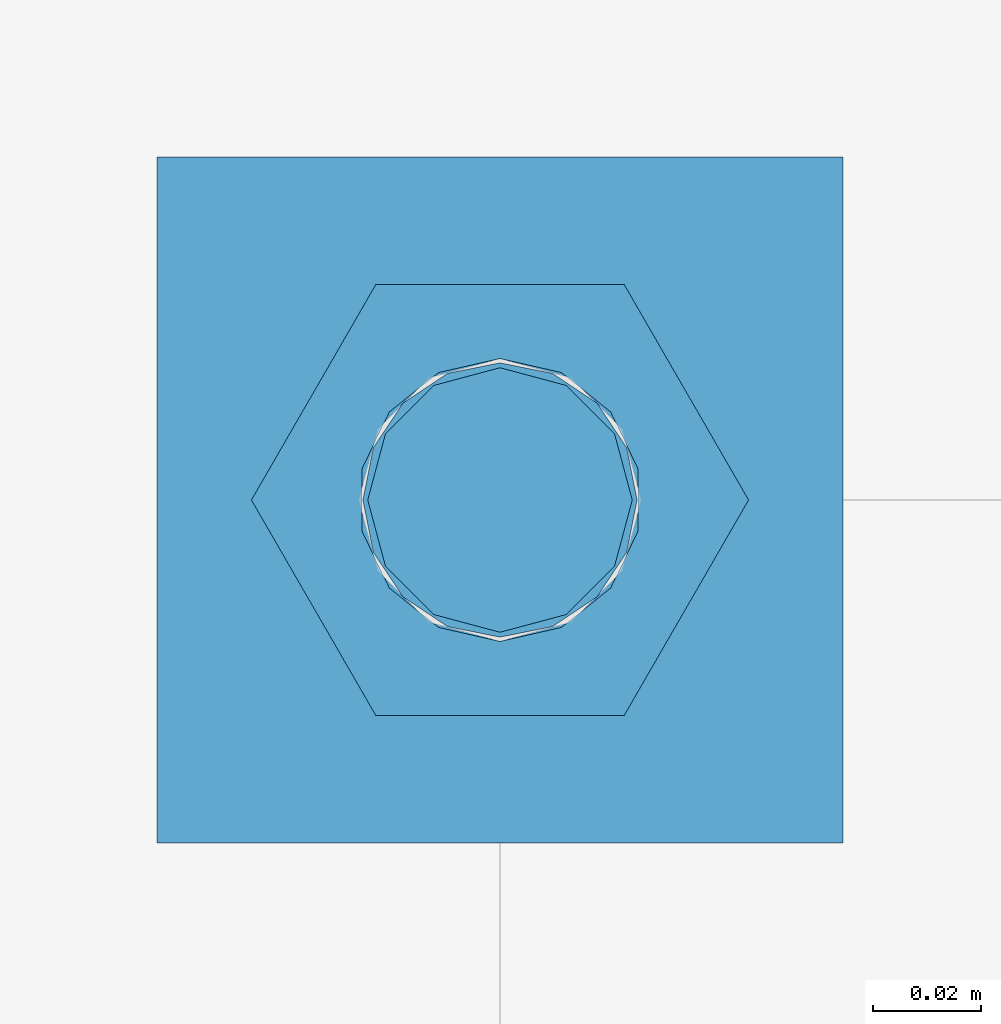
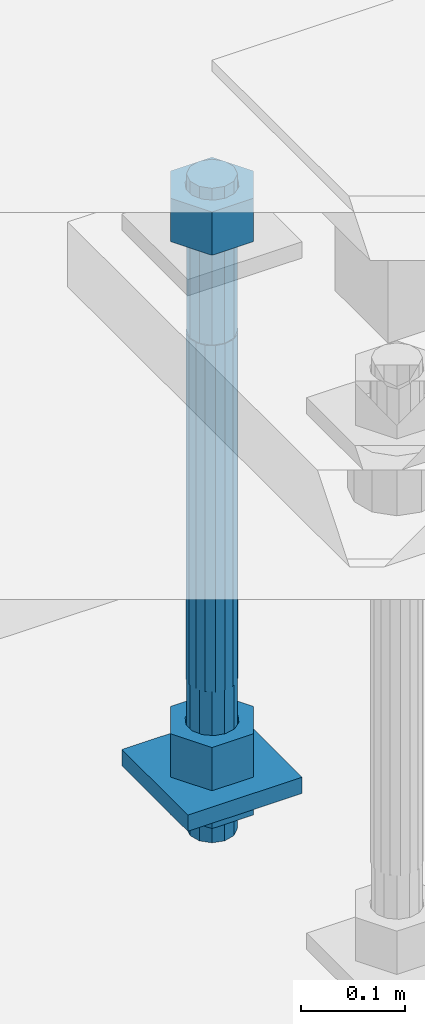
# One storey, part 2772 of 3843: 5 beams, 1 element without a shape of its own.
"""IFC2X3 building model written with IfcOpenShell, lengths in millimetres."""

from ifc_helpers import new_model, si_unit, frame, origin_with_axes, place, context, subcontext, project, spatial, faceted_brep, material, type_object, element, aggregate, save


model = new_model("IFC2X3")

# Units and contexts
model_context = context("Model", 3, precision=1e-05, world=origin_with_axes())
body_context = subcontext(model_context, "Body", "Model", "MODEL_VIEW")
ifc_project = project(units=[si_unit("LENGTHUNIT", "METRE", prefix="MILLI"), si_unit("AREAUNIT", "SQUARE_METRE"), si_unit("VOLUMEUNIT", "CUBIC_METRE"), si_unit("MASSUNIT", "GRAM", prefix="KILO"), si_unit("TIMEUNIT", "SECOND"), si_unit("PLANEANGLEUNIT", "RADIAN"), si_unit("SOLIDANGLEUNIT", "STERADIAN"), si_unit("THERMODYNAMICTEMPERATUREUNIT", "DEGREE_CELSIUS"), si_unit("LUMINOUSINTENSITYUNIT", "LUMEN")], contexts=[model_context])

# Site, building, storey
site_placement = place(None, origin_with_axes())
site = spatial("IfcSite", under=ifc_project, at=site_placement, CompositionType="ELEMENT")
building_placement = place(site_placement, origin_with_axes())
building = spatial("IfcBuilding", under=site, at=building_placement, Name="Undefined", CompositionType="ELEMENT")
storey_placement = place(building_placement, origin_with_axes())
storey = spatial("IfcBuildingStorey", under=building, at=storey_placement, Name="Undefined", CompositionType="ELEMENT", Elevation=0.0)

# Assembly, beams
assembly_placement = place(storey_placement, origin_with_axes())
assembly = element("IfcElementAssembly", 1, at=assembly_placement, inside=storey, Name="TEMPLATE", AssemblyPlace="NOTDEFINED", PredefinedType="RIGID_FRAME")
ifc_material_1 = material(Name="STEEL/A572-50")
beam_type_1 = type_object("IfcBeamType", PredefinedType="NOTDEFINED")
beam_1_placement = place(assembly_placement, frame((118598.95, 52946.2999984741, 29244.925), z_axis=(-1.0, 0.0, 0.0), x_axis=(0.0, -1.0, 0.0)))
beam_1 = element("IfcBeam", 2, at=beam_1_placement, type_object=beam_type_1, material=ifc_material_1, Name="WASHER_PLATE", context=body_context, shape_type="Brep", body=[
    faceted_brep([(0.0, 9.52500000000146, -63.5), (0.0, 9.52500000000146, 63.5), (127.0, 9.52500000000146, 63.5), (127.0, 9.52500000000146, -63.5), (0.0, -9.52500000000146, 63.5), (127.0, -9.52500000000146, 63.5), (0.0, -9.52500000000146, -63.5), (127.0, -9.52500000000146, -63.5)], [[[0, 1, 2, 3]], [[1, 4, 5, 2]], [[4, 6, 7, 5]], [[6, 0, 3, 7]], [[5, 7, 3, 2]], [[6, 4, 1, 0]]]),
])
ifc_material_2 = material(Name="STEEL/A36")
beam_type_2 = type_object("IfcBeamType", Name="2_HALF_NUT", PredefinedType="NOTDEFINED")
beam_2_placement = place(assembly_placement, frame((118598.95, 52882.7999984741, 29235.4), z_axis=(0.0, -1.0, 0.0), x_axis=(0.0, 0.0, -1.0)))
beam_2 = element("IfcBeam", 3, at=beam_2_placement, type_object=beam_type_2, material=ifc_material_2, Name="NUT", ObjectType="2_HALF_NUT", context=body_context, shape_type="Brep", body=[
    faceted_brep([(0.0, -46.0369987487793, 0.0), (0.0, -23.0184993743896, -39.869213104248), (25.4000000000015, -23.0184993743896, -39.869213104248), (25.4000000000015, -46.0369987487793, 0.0), (0.0, 23.0184993743896, -39.869213104248), (25.4000000000015, 23.0184993743896, -39.869213104248), (0.0, 46.0369987487793, 0.0), (25.4000000000015, 46.0369987487793, 0.0), (0.0, 23.0184993743896, 39.869213104248), (25.4000000000015, 23.0184993743896, 39.869213104248), (0.0, -23.0184993743896, 39.869213104248), (25.4000000000015, -23.0184993743896, 39.869213104248), (0.0, 0.0, 26.1940002441406), (0.0, 11.3650617044477, 23.5999013092805), (25.4000000000015, 11.3650617044477, 23.5999013092805), (25.4000000000015, 0.0, 26.1940002441406), (0.0, 20.4791109456419, 16.3316083006721), (25.4000000000015, 20.4791109456419, 16.3316083006721), (0.0, 25.5370200498292, 5.82867859874386), (25.4000000000015, 25.5370200498292, 5.82867859874386), (0.0, 25.5370200498292, -5.82867859874386), (25.4000000000015, 25.5370200498292, -5.82867859874386), (0.0, 20.4791109456419, -16.3316083006721), (25.4000000000015, 20.4791109456419, -16.3316083006721), (0.0, 11.3650617044477, -23.5999013092805), (25.4000000000015, 11.3650617044477, -23.5999013092805), (0.0, 0.0, -26.1940002441406), (25.4000000000015, 0.0, -26.1940002441406), (0.0, -11.3650617044477, -23.5999013092805), (25.4000000000015, -11.3650617044477, -23.5999013092805), (0.0, -20.4791109456419, -16.3316083006721), (25.4000000000015, -20.4791109456419, -16.3316083006721), (0.0, -25.5370200498292, -5.82867859874386), (25.4000000000015, -25.5370200498292, -5.82867859874386), (0.0, -25.5370200498292, 5.82867859874386), (25.4000000000015, -25.5370200498292, 5.82867859874386), (0.0, -20.4791109456419, 16.3316083006721), (25.4000000000015, -20.4791109456419, 16.3316083006721), (0.0, -11.3650617044477, 23.5999013092805), (25.4000000000015, -11.3650617044477, 23.5999013092805)], [[[0, 1, 2, 3]], [[1, 4, 5, 2]], [[4, 6, 7, 5]], [[6, 8, 9, 7]], [[8, 10, 11, 9]], [[10, 0, 3, 11]], [[12, 13, 14, 15]], [[13, 16, 17, 14]], [[16, 18, 19, 17]], [[18, 20, 21, 19]], [[20, 22, 23, 21]], [[22, 24, 25, 23]], [[24, 26, 27, 25]], [[26, 28, 29, 27]], [[28, 30, 31, 29]], [[30, 32, 33, 31]], [[32, 34, 35, 33]], [[34, 36, 37, 35]], [[36, 38, 39, 37]], [[38, 12, 15, 39]], [[5, 7, 9, 11, 3, 2], [17, 19, 21, 23, 25, 27, 29, 31, 33, 35, 37, 39, 15, 14]], [[10, 8, 6, 4, 1, 0], [38, 36, 34, 32, 30, 28, 26, 24, 22, 20, 18, 16, 13, 12]]]),
])
beam_type_3 = type_object("IfcBeamType", Name="2_HEAVY_HEX_NUT", PredefinedType="NOTDEFINED")
beam_3_placement = place(assembly_placement, frame((118598.95, 52882.7999984741, 29933.9), z_axis=(0.0, -1.0, 0.0), x_axis=(0.0, 0.0, -1.0)))
beam_3 = element("IfcBeam", 4, at=beam_3_placement, type_object=beam_type_3, material=ifc_material_2, Name="NUT", ObjectType="2_HEAVY_HEX_NUT", context=body_context, shape_type="Brep", body=[
    faceted_brep([(0.0, -46.0369987487793, 0.0), (0.0, -23.0184993743896, -39.869213104248), (50.7999999999993, -23.0184993743896, -39.869213104248), (50.7999999999993, -46.0369987487793, 0.0), (0.0, 23.0184993743896, -39.869213104248), (50.7999999999993, 23.0184993743896, -39.869213104248), (0.0, 46.0369987487793, 0.0), (50.7999999999993, 46.0369987487793, 0.0), (0.0, 23.0184993743896, 39.869213104248), (50.7999999999993, 23.0184993743896, 39.869213104248), (0.0, -23.0184993743896, 39.869213104248), (50.7999999999993, -23.0184993743896, 39.869213104248), (0.0, 0.0, 26.1940002441406), (0.0, 11.3650617044477, 23.5999013092805), (50.7999999999993, 11.3650617044477, 23.5999013092805), (50.7999999999993, 0.0, 26.1940002441406), (0.0, 20.4791109456419, 16.3316083006721), (50.7999999999993, 20.4791109456419, 16.3316083006721), (0.0, 25.5370200498292, 5.82867859874386), (50.7999999999993, 25.5370200498292, 5.82867859874386), (0.0, 25.5370200498292, -5.82867859874386), (50.7999999999993, 25.5370200498292, -5.82867859874386), (0.0, 20.4791109456419, -16.3316083006721), (50.7999999999993, 20.4791109456419, -16.3316083006721), (0.0, 11.3650617044477, -23.5999013092805), (50.7999999999993, 11.3650617044477, -23.5999013092805), (0.0, 0.0, -26.1940002441406), (50.7999999999993, 0.0, -26.1940002441406), (0.0, -11.3650617044477, -23.5999013092805), (50.7999999999993, -11.3650617044477, -23.5999013092805), (0.0, -20.4791109456419, -16.3316083006721), (50.7999999999993, -20.4791109456419, -16.3316083006721), (0.0, -25.5370200498292, -5.82867859874386), (50.7999999999993, -25.5370200498292, -5.82867859874386), (0.0, -25.5370200498292, 5.82867859874386), (50.7999999999993, -25.5370200498292, 5.82867859874386), (0.0, -20.4791109456419, 16.3316083006721), (50.7999999999993, -20.4791109456419, 16.3316083006721), (0.0, -11.3650617044477, 23.5999013092805), (50.7999999999993, -11.3650617044477, 23.5999013092805)], [[[0, 1, 2, 3]], [[1, 4, 5, 2]], [[4, 6, 7, 5]], [[6, 8, 9, 7]], [[8, 10, 11, 9]], [[10, 0, 3, 11]], [[12, 13, 14, 15]], [[13, 16, 17, 14]], [[16, 18, 19, 17]], [[18, 20, 21, 19]], [[20, 22, 23, 21]], [[22, 24, 25, 23]], [[24, 26, 27, 25]], [[26, 28, 29, 27]], [[28, 30, 31, 29]], [[30, 32, 33, 31]], [[32, 34, 35, 33]], [[34, 36, 37, 35]], [[36, 38, 39, 37]], [[38, 12, 15, 39]], [[5, 7, 9, 11, 3, 2], [17, 19, 21, 23, 25, 27, 29, 31, 33, 35, 37, 39, 15, 14]], [[10, 8, 6, 4, 1, 0], [38, 36, 34, 32, 30, 28, 26, 24, 22, 20, 18, 16, 13, 12]]]),
])
beam_4_placement = place(assembly_placement, frame((118598.95, 52882.7999984741, 29305.25), z_axis=(0.0, -1.0, 0.0), x_axis=(0.0, 0.0, -1.0)))
beam_4 = element("IfcBeam", 5, at=beam_4_placement, type_object=beam_type_3, material=ifc_material_2, Name="NUT", ObjectType="2_HEAVY_HEX_NUT", context=body_context, shape_type="Brep", body=[
    faceted_brep([(0.0, -46.0369987487793, 0.0), (0.0, -23.0184993743896, -39.869213104248), (50.7999999999993, -23.0184993743896, -39.869213104248), (50.7999999999993, -46.0369987487793, 0.0), (0.0, 23.0184993743896, -39.869213104248), (50.7999999999993, 23.0184993743896, -39.869213104248), (0.0, 46.0369987487793, 0.0), (50.7999999999993, 46.0369987487793, 0.0), (0.0, 23.0184993743896, 39.869213104248), (50.7999999999993, 23.0184993743896, 39.869213104248), (0.0, -23.0184993743896, 39.869213104248), (50.7999999999993, -23.0184993743896, 39.869213104248), (0.0, 0.0, 26.1940002441406), (0.0, 11.3650617044477, 23.5999013092805), (50.7999999999993, 11.3650617044477, 23.5999013092805), (50.7999999999993, 0.0, 26.1940002441406), (0.0, 20.4791109456419, 16.3316083006721), (50.7999999999993, 20.4791109456419, 16.3316083006721), (0.0, 25.5370200498292, 5.82867859874386), (50.7999999999993, 25.5370200498292, 5.82867859874386), (0.0, 25.5370200498292, -5.82867859874386), (50.7999999999993, 25.5370200498292, -5.82867859874386), (0.0, 20.4791109456419, -16.3316083006721), (50.7999999999993, 20.4791109456419, -16.3316083006721), (0.0, 11.3650617044477, -23.5999013092805), (50.7999999999993, 11.3650617044477, -23.5999013092805), (0.0, 0.0, -26.1940002441406), (50.7999999999993, 0.0, -26.1940002441406), (0.0, -11.3650617044477, -23.5999013092805), (50.7999999999993, -11.3650617044477, -23.5999013092805), (0.0, -20.4791109456419, -16.3316083006721), (50.7999999999993, -20.4791109456419, -16.3316083006721), (0.0, -25.5370200498292, -5.82867859874386), (50.7999999999993, -25.5370200498292, -5.82867859874386), (0.0, -25.5370200498292, 5.82867859874386), (50.7999999999993, -25.5370200498292, 5.82867859874386), (0.0, -20.4791109456419, 16.3316083006721), (50.7999999999993, -20.4791109456419, 16.3316083006721), (0.0, -11.3650617044477, 23.5999013092805), (50.7999999999993, -11.3650617044477, 23.5999013092805)], [[[0, 1, 2, 3]], [[1, 4, 5, 2]], [[4, 6, 7, 5]], [[6, 8, 9, 7]], [[8, 10, 11, 9]], [[10, 0, 3, 11]], [[12, 13, 14, 15]], [[13, 16, 17, 14]], [[16, 18, 19, 17]], [[18, 20, 21, 19]], [[20, 22, 23, 21]], [[22, 24, 25, 23]], [[24, 26, 27, 25]], [[26, 28, 29, 27]], [[28, 30, 31, 29]], [[30, 32, 33, 31]], [[32, 34, 35, 33]], [[34, 36, 37, 35]], [[36, 38, 39, 37]], [[38, 12, 15, 39]], [[5, 7, 9, 11, 3, 2], [17, 19, 21, 23, 25, 27, 29, 31, 33, 35, 37, 39, 15, 14]], [[10, 8, 6, 4, 1, 0], [38, 36, 34, 32, 30, 28, 26, 24, 22, 20, 18, 16, 13, 12]]]),
])
ifc_material_3 = material()
beam_type_4 = type_object("IfcBeamType", PredefinedType="NOTDEFINED")
beam_5_placement = place(assembly_placement, frame((118598.95, 52882.7999984741, 29762.45), z_axis=(0.0, -1.0, 0.0), x_axis=(0.0, 0.0, -1.0)))
beam_5 = element("IfcBeam", 6, at=beam_5_placement, type_object=beam_type_4, material=ifc_material_3, Name="ANCHOR_ROD", context=body_context, shape_type="Brep", body=[
    faceted_brep([(-184.150000000001, -21.217622392709, 12.25), (-184.150000000001, -12.2499999999854, 21.2176223927163), (-184.150000000001, 1.45519152283669e-11, 24.5), (-184.150000000001, 12.2500000000146, 21.2176223927163), (-184.150000000001, 21.2176223927381, 12.25), (-184.150000000001, 24.5000000000146, 0.0), (-184.150000000001, 21.2176223927381, -12.25), (-184.150000000001, 12.2500000000146, -21.2176223927163), (-184.150000000001, 1.45519152283669e-11, -24.5), (-184.150000000001, -12.2499999999854, -21.2176223927163), (-184.150000000001, -21.217622392709, -12.25), (-184.150000000001, -24.4999999999854, 0.0), (0.0, 24.5000000000146, 0.0), (0.0, 21.2176223927381, -12.25), (0.0, 12.2500000000146, -21.2176223927163), (0.0, 1.45519152283669e-11, -24.5), (0.0, -12.2499999999854, -21.2176223927163), (0.0, -21.217622392709, -12.25), (0.0, -24.4999999999854, 0.0), (0.0, -21.217622392709, 12.25), (0.0, -12.2499999999854, 21.2176223927163), (0.0, 1.45519152283669e-11, 24.5), (0.0, 12.2500000000146, 21.2176223927163), (0.0, 21.2176223927381, 12.25), (0.0, -23.4665401257807, 9.72015918207035), (0.0, -17.9605122421344, 17.9605122421417), (0.0, -9.72015918207762, 23.466540125788), (0.0, 0.0, 25.4000000000015), (0.0, 9.72015918207762, 23.466540125788), (0.0, 17.9605122421344, 17.9605122421417), (0.0, 23.4665401257807, 9.72015918207035), (0.0, 25.3999996185303, 0.0), (0.0, 23.4665401257807, -9.72015918207035), (0.0, 17.9605122421344, -17.9605122421417), (0.0, 9.72015918207762, -23.466540125788), (0.0, 0.0, -25.4000000000015), (0.0, -9.72015918207762, -23.466540125788), (0.0, -17.9605122421344, -17.9605122421417), (0.0, -23.4665401257807, -9.72015918207035), (0.0, -25.3999996185303, 0.0), (406.399999999998, -25.3999999999942, 0.0), (406.399999999998, -23.4665401257807, 9.72015918207035), (406.399999999998, -17.9605122421344, 17.9605122421417), (406.399999999998, -9.72015918207762, 23.466540125788), (406.399999999998, 0.0, 25.4000000000015), (406.399999999998, 9.72015918207762, 23.466540125788), (406.399999999998, 17.9605122421344, 17.9605122421417), (406.399999999998, 23.4665401257807, 9.72015918207035), (406.399999999998, 25.3999999999942, 0.0), (406.399999999998, 23.4665401257807, -9.72015918207035), (406.399999999998, 17.9605122421344, -17.9605122421417), (406.399999999998, 9.72015918207762, -23.466540125788), (406.399999999998, 0.0, -25.4000000000015), (406.399999999998, -9.72015918207762, -23.466540125788), (406.399999999998, -17.9605122421344, -17.9605122421417), (406.399999999998, -23.4665401257807, -9.72015918207035), (406.399999999998, -12.2499999999854, 21.2176223927163), (406.399999999998, 1.45519152283669e-11, 24.5), (406.399999999998, 12.2500000000146, 21.2176223927163), (406.399999999998, 21.2176223927381, 12.25), (406.399999999998, 24.5000000000146, 0.0), (406.399999999998, 21.2176223927381, -12.25), (406.399999999998, 12.2500000000146, -21.2176223927163), (406.399999999998, 1.45519152283669e-11, -24.5), (406.399999999998, -12.2499999999854, -21.2176223927163), (406.399999999998, -21.217622392709, -12.25), (406.399999999998, -24.4999999999854, 0.0), (406.399999999998, -21.217622392709, 12.25), (584.200000000001, -12.2499999999854, -21.2176223927163), (584.200000000001, 1.45519152283669e-11, -24.5), (584.200000000001, 12.2500000000146, -21.2176223927163), (584.200000000001, 21.2176223927381, -12.25), (584.200000000001, 24.5000000000146, 0.0), (584.200000000001, 21.2176223927381, 12.25), (584.200000000001, 12.2500000000146, 21.2176223927163), (584.200000000001, 1.45519152283669e-11, 24.5), (584.200000000001, -12.2499999999854, 21.2176223927163), (584.200000000001, -21.217622392709, 12.25), (584.200000000001, -24.4999999999854, 0.0), (584.200000000001, -21.217622392709, -12.25)], [[[0, 1, 2, 3, 4, 5, 6, 7, 8, 9, 10, 11]], [[6, 5, 12, 13]], [[7, 6, 13, 14]], [[8, 7, 14, 15]], [[9, 8, 15, 16]], [[10, 9, 16, 17]], [[11, 10, 17, 18]], [[0, 11, 18, 19]], [[1, 0, 19, 20]], [[2, 1, 20, 21]], [[3, 2, 21, 22]], [[4, 3, 22, 23]], [[5, 4, 23, 12]], [[24, 25, 26, 27, 28, 29, 30, 31, 32, 33, 34, 35, 36, 37, 38, 39], [22, 21, 20, 19, 18, 17, 16, 15, 14, 13, 12, 23]], [[24, 39, 40, 41]], [[25, 24, 41, 42]], [[26, 25, 42, 43]], [[27, 26, 43, 44]], [[28, 27, 44, 45]], [[29, 28, 45, 46]], [[30, 29, 46, 47]], [[31, 30, 47, 48]], [[32, 31, 48, 49]], [[33, 32, 49, 50]], [[34, 33, 50, 51]], [[35, 34, 51, 52]], [[36, 35, 52, 53]], [[37, 36, 53, 54]], [[38, 37, 54, 55]], [[39, 38, 55, 40]], [[54, 53, 52, 51, 50, 49, 48, 47, 46, 45, 44, 43, 42, 41, 40, 55], [56, 57, 58, 59, 60, 61, 62, 63, 64, 65, 66, 67]], [[68, 69, 70, 71, 72, 73, 74, 75, 76, 77, 78, 79]], [[76, 75, 57, 56]], [[77, 76, 56, 67]], [[78, 77, 67, 66]], [[79, 78, 66, 65]], [[68, 79, 65, 64]], [[69, 68, 64, 63]], [[70, 69, 63, 62]], [[71, 70, 62, 61]], [[72, 71, 61, 60]], [[73, 72, 60, 59]], [[74, 73, 59, 58]], [[75, 74, 58, 57]]]),
])
aggregate(assembly, [beam_3, beam_4, beam_2, beam_1, beam_5])

save(model, "model.ifc")
